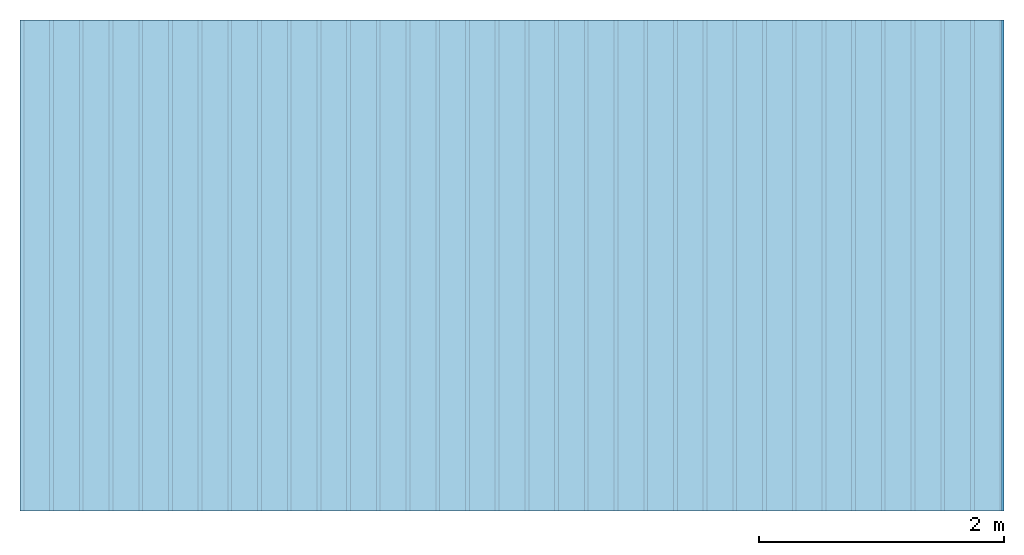
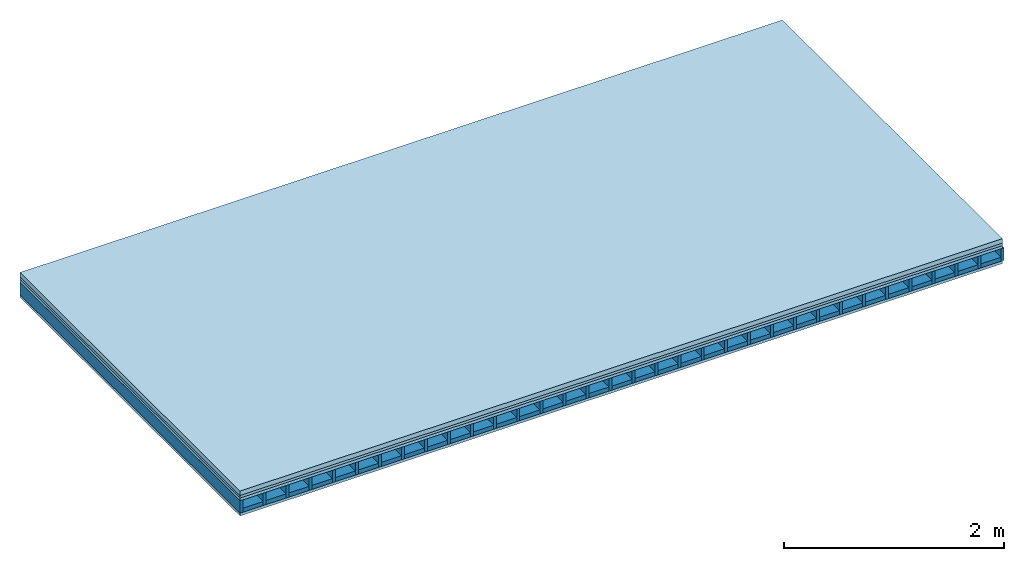
# One storey: 4 plates, 2 members, 1 element without a shape of its own.
"""IFC4 building model written with IfcOpenShell, lengths in metres."""

from ifc_helpers import new_model, si_unit, derived_unit, direction, frame, frame_2d, origin, origin_with_axes, place, context, project, spatial, rectangle, extrude, material, layer, layer_set, type_object, element, aggregate, save


model = new_model("IFC4")

# Units and contexts
plan_context = context("Plan", 3, precision=1e-05, world=origin(), true_north=direction((0.0, 1.0)))
model_context = context("Model", 3, precision=1e-05, world=origin(), true_north=direction((0.0, 1.0)))
ifc_project = project(units=[si_unit("LENGTHUNIT", "METRE"), derived_unit("SOUNDPRESSUREUNIT", [(si_unit("PRESSUREUNIT", "PASCAL", prefix="MICRO"), 0)]), si_unit("ENERGYUNIT", "JOULE", prefix="MEGA"), si_unit("MASSUNIT", "GRAM", prefix="KILO"), derived_unit("THERMALTRANSMITTANCEUNIT", [(si_unit("POWERUNIT", "WATT"), 1), (si_unit("AREAUNIT", "SQUARE_METRE"), -1), (si_unit("THERMODYNAMICTEMPERATUREUNIT", "KELVIN"), -1)]), derived_unit("AREADENSITYUNIT", [(si_unit("MASSUNIT", "GRAM", prefix="KILO"), 1), (si_unit("AREAUNIT", "SQUARE_METRE"), -1)]), derived_unit("USERDEFINED", [(si_unit("ENERGYUNIT", "JOULE", prefix="MEGA"), 1), (si_unit("AREAUNIT", "SQUARE_METRE"), -1)])], contexts=[plan_context, model_context])

# Site, building, storey
site = spatial("IfcSite", under=ifc_project)
building_placement = place(None, origin())
building = spatial("IfcBuilding", under=site, at=building_placement)
storey_placement = place(building_placement, origin())
storey = spatial("IfcBuildingStorey", under=building, at=storey_placement)

# Slab, members, plates
ifc_material_1 = material(Name="Cement screed", Category="04.006")
ifc_layer_1 = layer(ifc_material_1, 0.05, Name="On-material")
ifc_material_2 = material()
ifc_layer_2 = layer(ifc_material_2, 0.027, Name="Impact sound insulation")
ifc_material_3 = material(Name="surface element sheathing above")
ifc_layer_3 = layer(ifc_material_3, 0.031, Name="Sub-floor")
ifc_layer_4 = layer(None, 0.138, Name="Supporting structure")
ifc_material_4 = material(Name="surface element sheathing below")
ifc_layer_5 = layer(ifc_material_4, 0.031, Name="Lower layer 1")
ifc_layer_set = layer_set([ifc_layer_1, ifc_layer_2, ifc_layer_3, ifc_layer_4, ifc_layer_5])
slab_type = type_object("IfcSlabType", Name="A0030", PredefinedType="NOTDEFINED", material=ifc_layer_set)
slab_placement = place(None, frame((0.0, 0.0, 0.0), z_axis=(0.0, 0.0, -1.0), x_axis=(1.0, 0.0, 0.0)))
slab = element("IfcSlab", 1, at=slab_placement, inside=storey, type_object=slab_type, material=ifc_layer_set, Name="Slab #1")
ifc_material_5 = material(Name="surface element LFE")
member_1_placement = place(slab_placement, origin())
member_1 = element("IfcMember", 2, at=member_1_placement, material=ifc_material_5, Name="Supporting structure", context=plan_context, shape_type="SweptSolid", body=[
    extrude(rectangle(XDim=0.031, YDim=0.138, at=frame_2d((0.0155, 0.069), x_axis=(1.0, 0.0))), frame((0.0, 4.0, 0.108), z_axis=(0.0, -1.0, 0.0), x_axis=(1.0, 0.0, 0.0)), (0.0, 0.0, 1.0), 4.0),
    extrude(rectangle(XDim=0.031, YDim=0.138, at=frame_2d((0.0155, 0.069), x_axis=(1.0, 0.0))), frame((0.242, 4.0, 0.108), z_axis=(0.0, -1.0, 0.0), x_axis=(1.0, 0.0, 0.0)), (0.0, 0.0, 1.0), 4.0),
    extrude(rectangle(XDim=0.031, YDim=0.138, at=frame_2d((0.0155, 0.069), x_axis=(1.0, 0.0))), frame((0.484, 4.0, 0.108), z_axis=(0.0, -1.0, 0.0), x_axis=(1.0, 0.0, 0.0)), (0.0, 0.0, 1.0), 4.0),
    extrude(rectangle(XDim=0.031, YDim=0.138, at=frame_2d((0.0155, 0.069), x_axis=(1.0, 0.0))), frame((0.726, 4.0, 0.108), z_axis=(0.0, -1.0, 0.0), x_axis=(1.0, 0.0, 0.0)), (0.0, 0.0, 1.0), 4.0),
    extrude(rectangle(XDim=0.031, YDim=0.138, at=frame_2d((0.0155, 0.069), x_axis=(1.0, 0.0))), frame((0.968, 4.0, 0.108), z_axis=(0.0, -1.0, 0.0), x_axis=(1.0, 0.0, 0.0)), (0.0, 0.0, 1.0), 4.0),
    extrude(rectangle(XDim=0.031, YDim=0.138, at=frame_2d((0.0155, 0.069), x_axis=(1.0, 0.0))), frame((1.21, 4.0, 0.108), z_axis=(0.0, -1.0, 0.0), x_axis=(1.0, 0.0, 0.0)), (0.0, 0.0, 1.0), 4.0),
    extrude(rectangle(XDim=0.031, YDim=0.138, at=frame_2d((0.0155, 0.069), x_axis=(1.0, 0.0))), frame((1.452, 4.0, 0.108), z_axis=(0.0, -1.0, 0.0), x_axis=(1.0, 0.0, 0.0)), (0.0, 0.0, 1.0), 4.0),
    extrude(rectangle(XDim=0.031, YDim=0.138, at=frame_2d((0.0155, 0.069), x_axis=(1.0, 0.0))), frame((1.694, 4.0, 0.108), z_axis=(0.0, -1.0, 0.0), x_axis=(1.0, 0.0, 0.0)), (0.0, 0.0, 1.0), 4.0),
    extrude(rectangle(XDim=0.031, YDim=0.138, at=frame_2d((0.0155, 0.069), x_axis=(1.0, 0.0))), frame((1.936, 4.0, 0.108), z_axis=(0.0, -1.0, 0.0), x_axis=(1.0, 0.0, 0.0)), (0.0, 0.0, 1.0), 4.0),
    extrude(rectangle(XDim=0.031, YDim=0.138, at=frame_2d((0.0155, 0.069), x_axis=(1.0, 0.0))), frame((2.178, 4.0, 0.108), z_axis=(0.0, -1.0, 0.0), x_axis=(1.0, 0.0, 0.0)), (0.0, 0.0, 1.0), 4.0),
    extrude(rectangle(XDim=0.031, YDim=0.138, at=frame_2d((0.0155, 0.069), x_axis=(1.0, 0.0))), frame((2.42, 4.0, 0.108), z_axis=(0.0, -1.0, 0.0), x_axis=(1.0, 0.0, 0.0)), (0.0, 0.0, 1.0), 4.0),
    extrude(rectangle(XDim=0.031, YDim=0.138, at=frame_2d((0.0155, 0.069), x_axis=(1.0, 0.0))), frame((2.662, 4.0, 0.108), z_axis=(0.0, -1.0, 0.0), x_axis=(1.0, 0.0, 0.0)), (0.0, 0.0, 1.0), 4.0),
    extrude(rectangle(XDim=0.031, YDim=0.138, at=frame_2d((0.0155, 0.069), x_axis=(1.0, 0.0))), frame((2.904, 4.0, 0.108), z_axis=(0.0, -1.0, 0.0), x_axis=(1.0, 0.0, 0.0)), (0.0, 0.0, 1.0), 4.0),
    extrude(rectangle(XDim=0.031, YDim=0.138, at=frame_2d((0.0155, 0.069), x_axis=(1.0, 0.0))), frame((3.146, 4.0, 0.108), z_axis=(0.0, -1.0, 0.0), x_axis=(1.0, 0.0, 0.0)), (0.0, 0.0, 1.0), 4.0),
    extrude(rectangle(XDim=0.031, YDim=0.138, at=frame_2d((0.0155, 0.069), x_axis=(1.0, 0.0))), frame((3.388, 4.0, 0.108), z_axis=(0.0, -1.0, 0.0), x_axis=(1.0, 0.0, 0.0)), (0.0, 0.0, 1.0), 4.0),
    extrude(rectangle(XDim=0.031, YDim=0.138, at=frame_2d((0.0155, 0.069), x_axis=(1.0, 0.0))), frame((3.63, 4.0, 0.108), z_axis=(0.0, -1.0, 0.0), x_axis=(1.0, 0.0, 0.0)), (0.0, 0.0, 1.0), 4.0),
    extrude(rectangle(XDim=0.031, YDim=0.138, at=frame_2d((0.0155, 0.069), x_axis=(1.0, 0.0))), frame((3.872, 4.0, 0.108), z_axis=(0.0, -1.0, 0.0), x_axis=(1.0, 0.0, 0.0)), (0.0, 0.0, 1.0), 4.0),
    extrude(rectangle(XDim=0.031, YDim=0.138, at=frame_2d((0.0155, 0.069), x_axis=(1.0, 0.0))), frame((4.114, 4.0, 0.108), z_axis=(0.0, -1.0, 0.0), x_axis=(1.0, 0.0, 0.0)), (0.0, 0.0, 1.0), 4.0),
    extrude(rectangle(XDim=0.031, YDim=0.138, at=frame_2d((0.0155, 0.069), x_axis=(1.0, 0.0))), frame((4.356, 4.0, 0.108), z_axis=(0.0, -1.0, 0.0), x_axis=(1.0, 0.0, 0.0)), (0.0, 0.0, 1.0), 4.0),
    extrude(rectangle(XDim=0.031, YDim=0.138, at=frame_2d((0.0155, 0.069), x_axis=(1.0, 0.0))), frame((4.598, 4.0, 0.108), z_axis=(0.0, -1.0, 0.0), x_axis=(1.0, 0.0, 0.0)), (0.0, 0.0, 1.0), 4.0),
    extrude(rectangle(XDim=0.031, YDim=0.138, at=frame_2d((0.0155, 0.069), x_axis=(1.0, 0.0))), frame((4.84, 4.0, 0.108), z_axis=(0.0, -1.0, 0.0), x_axis=(1.0, 0.0, 0.0)), (0.0, 0.0, 1.0), 4.0),
    extrude(rectangle(XDim=0.031, YDim=0.138, at=frame_2d((0.0155, 0.069), x_axis=(1.0, 0.0))), frame((5.082, 4.0, 0.108), z_axis=(0.0, -1.0, 0.0), x_axis=(1.0, 0.0, 0.0)), (0.0, 0.0, 1.0), 4.0),
    extrude(rectangle(XDim=0.031, YDim=0.138, at=frame_2d((0.0155, 0.069), x_axis=(1.0, 0.0))), frame((5.324, 4.0, 0.108), z_axis=(0.0, -1.0, 0.0), x_axis=(1.0, 0.0, 0.0)), (0.0, 0.0, 1.0), 4.0),
    extrude(rectangle(XDim=0.031, YDim=0.138, at=frame_2d((0.0155, 0.069), x_axis=(1.0, 0.0))), frame((5.566, 4.0, 0.108), z_axis=(0.0, -1.0, 0.0), x_axis=(1.0, 0.0, 0.0)), (0.0, 0.0, 1.0), 4.0),
    extrude(rectangle(XDim=0.031, YDim=0.138, at=frame_2d((0.0155, 0.069), x_axis=(1.0, 0.0))), frame((5.808, 4.0, 0.108), z_axis=(0.0, -1.0, 0.0), x_axis=(1.0, 0.0, 0.0)), (0.0, 0.0, 1.0), 4.0),
    extrude(rectangle(XDim=0.031, YDim=0.138, at=frame_2d((0.0155, 0.069), x_axis=(1.0, 0.0))), frame((6.05, 4.0, 0.108), z_axis=(0.0, -1.0, 0.0), x_axis=(1.0, 0.0, 0.0)), (0.0, 0.0, 1.0), 4.0),
    extrude(rectangle(XDim=0.031, YDim=0.138, at=frame_2d((0.0155, 0.069), x_axis=(1.0, 0.0))), frame((6.292, 4.0, 0.108), z_axis=(0.0, -1.0, 0.0), x_axis=(1.0, 0.0, 0.0)), (0.0, 0.0, 1.0), 4.0),
    extrude(rectangle(XDim=0.031, YDim=0.138, at=frame_2d((0.0155, 0.069), x_axis=(1.0, 0.0))), frame((6.534, 4.0, 0.108), z_axis=(0.0, -1.0, 0.0), x_axis=(1.0, 0.0, 0.0)), (0.0, 0.0, 1.0), 4.0),
    extrude(rectangle(XDim=0.031, YDim=0.138, at=frame_2d((0.0155, 0.069), x_axis=(1.0, 0.0))), frame((6.776, 4.0, 0.108), z_axis=(0.0, -1.0, 0.0), x_axis=(1.0, 0.0, 0.0)), (0.0, 0.0, 1.0), 4.0),
    extrude(rectangle(XDim=0.031, YDim=0.138, at=frame_2d((0.0155, 0.069), x_axis=(1.0, 0.0))), frame((7.018, 4.0, 0.108), z_axis=(0.0, -1.0, 0.0), x_axis=(1.0, 0.0, 0.0)), (0.0, 0.0, 1.0), 4.0),
    extrude(rectangle(XDim=0.031, YDim=0.138, at=frame_2d((0.0155, 0.069), x_axis=(1.0, 0.0))), frame((7.26, 4.0, 0.108), z_axis=(0.0, -1.0, 0.0), x_axis=(1.0, 0.0, 0.0)), (0.0, 0.0, 1.0), 4.0),
    extrude(rectangle(XDim=0.031, YDim=0.138, at=frame_2d((0.0155, 0.069), x_axis=(1.0, 0.0))), frame((7.502, 4.0, 0.108), z_axis=(0.0, -1.0, 0.0), x_axis=(1.0, 0.0, 0.0)), (0.0, 0.0, 1.0), 4.0),
    extrude(rectangle(XDim=0.031, YDim=0.138, at=frame_2d((0.0155, 0.069), x_axis=(1.0, 0.0))), frame((7.744, 4.0, 0.108), z_axis=(0.0, -1.0, 0.0), x_axis=(1.0, 0.0, 0.0)), (0.0, 0.0, 1.0), 4.0),
    extrude(rectangle(XDim=0.031, YDim=0.138, at=frame_2d((0.0155, 0.069), x_axis=(1.0, 0.0))), frame((7.986, 4.0, 0.108), z_axis=(0.0, -1.0, 0.0), x_axis=(1.0, 0.0, 0.0)), (0.0, 0.0, 1.0), 4.0),
])
ifc_material_6 = material()
member_2_placement = place(slab_placement, origin())
member_2 = element("IfcMember", 3, at=member_2_placement, material=ifc_material_6, Name="in supporting structure", context=plan_context, shape_type="SweptSolid", body=[
    extrude(rectangle(XDim=0.211, YDim=0.045, at=frame_2d((0.1055, 0.0225), x_axis=(1.0, 0.0))), frame((0.031, 4.0, 0.201), z_axis=(0.0, -1.0, 0.0), x_axis=(1.0, 0.0, 0.0)), (0.0, 0.0, 1.0), 4.0),
    extrude(rectangle(XDim=0.211, YDim=0.045, at=frame_2d((0.1055, 0.0225), x_axis=(1.0, 0.0))), frame((0.273, 4.0, 0.201), z_axis=(0.0, -1.0, 0.0), x_axis=(1.0, 0.0, 0.0)), (0.0, 0.0, 1.0), 4.0),
    extrude(rectangle(XDim=0.211, YDim=0.045, at=frame_2d((0.1055, 0.0225), x_axis=(1.0, 0.0))), frame((0.515, 4.0, 0.201), z_axis=(0.0, -1.0, 0.0), x_axis=(1.0, 0.0, 0.0)), (0.0, 0.0, 1.0), 4.0),
    extrude(rectangle(XDim=0.211, YDim=0.045, at=frame_2d((0.1055, 0.0225), x_axis=(1.0, 0.0))), frame((0.757, 4.0, 0.201), z_axis=(0.0, -1.0, 0.0), x_axis=(1.0, 0.0, 0.0)), (0.0, 0.0, 1.0), 4.0),
    extrude(rectangle(XDim=0.211, YDim=0.045, at=frame_2d((0.1055, 0.0225), x_axis=(1.0, 0.0))), frame((0.999, 4.0, 0.201), z_axis=(0.0, -1.0, 0.0), x_axis=(1.0, 0.0, 0.0)), (0.0, 0.0, 1.0), 4.0),
    extrude(rectangle(XDim=0.211, YDim=0.045, at=frame_2d((0.1055, 0.0225), x_axis=(1.0, 0.0))), frame((1.241, 4.0, 0.201), z_axis=(0.0, -1.0, 0.0), x_axis=(1.0, 0.0, 0.0)), (0.0, 0.0, 1.0), 4.0),
    extrude(rectangle(XDim=0.211, YDim=0.045, at=frame_2d((0.1055, 0.0225), x_axis=(1.0, 0.0))), frame((1.483, 4.0, 0.201), z_axis=(0.0, -1.0, 0.0), x_axis=(1.0, 0.0, 0.0)), (0.0, 0.0, 1.0), 4.0),
    extrude(rectangle(XDim=0.211, YDim=0.045, at=frame_2d((0.1055, 0.0225), x_axis=(1.0, 0.0))), frame((1.725, 4.0, 0.201), z_axis=(0.0, -1.0, 0.0), x_axis=(1.0, 0.0, 0.0)), (0.0, 0.0, 1.0), 4.0),
    extrude(rectangle(XDim=0.211, YDim=0.045, at=frame_2d((0.1055, 0.0225), x_axis=(1.0, 0.0))), frame((1.967, 4.0, 0.201), z_axis=(0.0, -1.0, 0.0), x_axis=(1.0, 0.0, 0.0)), (0.0, 0.0, 1.0), 4.0),
    extrude(rectangle(XDim=0.211, YDim=0.045, at=frame_2d((0.1055, 0.0225), x_axis=(1.0, 0.0))), frame((2.209, 4.0, 0.201), z_axis=(0.0, -1.0, 0.0), x_axis=(1.0, 0.0, 0.0)), (0.0, 0.0, 1.0), 4.0),
    extrude(rectangle(XDim=0.211, YDim=0.045, at=frame_2d((0.1055, 0.0225), x_axis=(1.0, 0.0))), frame((2.451, 4.0, 0.201), z_axis=(0.0, -1.0, 0.0), x_axis=(1.0, 0.0, 0.0)), (0.0, 0.0, 1.0), 4.0),
    extrude(rectangle(XDim=0.211, YDim=0.045, at=frame_2d((0.1055, 0.0225), x_axis=(1.0, 0.0))), frame((2.693, 4.0, 0.201), z_axis=(0.0, -1.0, 0.0), x_axis=(1.0, 0.0, 0.0)), (0.0, 0.0, 1.0), 4.0),
    extrude(rectangle(XDim=0.211, YDim=0.045, at=frame_2d((0.1055, 0.0225), x_axis=(1.0, 0.0))), frame((2.935, 4.0, 0.201), z_axis=(0.0, -1.0, 0.0), x_axis=(1.0, 0.0, 0.0)), (0.0, 0.0, 1.0), 4.0),
    extrude(rectangle(XDim=0.211, YDim=0.045, at=frame_2d((0.1055, 0.0225), x_axis=(1.0, 0.0))), frame((3.177, 4.0, 0.201), z_axis=(0.0, -1.0, 0.0), x_axis=(1.0, 0.0, 0.0)), (0.0, 0.0, 1.0), 4.0),
    extrude(rectangle(XDim=0.211, YDim=0.045, at=frame_2d((0.1055, 0.0225), x_axis=(1.0, 0.0))), frame((3.419, 4.0, 0.201), z_axis=(0.0, -1.0, 0.0), x_axis=(1.0, 0.0, 0.0)), (0.0, 0.0, 1.0), 4.0),
    extrude(rectangle(XDim=0.211, YDim=0.045, at=frame_2d((0.1055, 0.0225), x_axis=(1.0, 0.0))), frame((3.661, 4.0, 0.201), z_axis=(0.0, -1.0, 0.0), x_axis=(1.0, 0.0, 0.0)), (0.0, 0.0, 1.0), 4.0),
    extrude(rectangle(XDim=0.211, YDim=0.045, at=frame_2d((0.1055, 0.0225), x_axis=(1.0, 0.0))), frame((3.903, 4.0, 0.201), z_axis=(0.0, -1.0, 0.0), x_axis=(1.0, 0.0, 0.0)), (0.0, 0.0, 1.0), 4.0),
    extrude(rectangle(XDim=0.211, YDim=0.045, at=frame_2d((0.1055, 0.0225), x_axis=(1.0, 0.0))), frame((4.145, 4.0, 0.201), z_axis=(0.0, -1.0, 0.0), x_axis=(1.0, 0.0, 0.0)), (0.0, 0.0, 1.0), 4.0),
    extrude(rectangle(XDim=0.211, YDim=0.045, at=frame_2d((0.1055, 0.0225), x_axis=(1.0, 0.0))), frame((4.387, 4.0, 0.201), z_axis=(0.0, -1.0, 0.0), x_axis=(1.0, 0.0, 0.0)), (0.0, 0.0, 1.0), 4.0),
    extrude(rectangle(XDim=0.211, YDim=0.045, at=frame_2d((0.1055, 0.0225), x_axis=(1.0, 0.0))), frame((4.629, 4.0, 0.201), z_axis=(0.0, -1.0, 0.0), x_axis=(1.0, 0.0, 0.0)), (0.0, 0.0, 1.0), 4.0),
    extrude(rectangle(XDim=0.211, YDim=0.045, at=frame_2d((0.1055, 0.0225), x_axis=(1.0, 0.0))), frame((4.871, 4.0, 0.201), z_axis=(0.0, -1.0, 0.0), x_axis=(1.0, 0.0, 0.0)), (0.0, 0.0, 1.0), 4.0),
    extrude(rectangle(XDim=0.211, YDim=0.045, at=frame_2d((0.1055, 0.0225), x_axis=(1.0, 0.0))), frame((5.113, 4.0, 0.201), z_axis=(0.0, -1.0, 0.0), x_axis=(1.0, 0.0, 0.0)), (0.0, 0.0, 1.0), 4.0),
    extrude(rectangle(XDim=0.211, YDim=0.045, at=frame_2d((0.1055, 0.0225), x_axis=(1.0, 0.0))), frame((5.355, 4.0, 0.201), z_axis=(0.0, -1.0, 0.0), x_axis=(1.0, 0.0, 0.0)), (0.0, 0.0, 1.0), 4.0),
    extrude(rectangle(XDim=0.211, YDim=0.045, at=frame_2d((0.1055, 0.0225), x_axis=(1.0, 0.0))), frame((5.597, 4.0, 0.201), z_axis=(0.0, -1.0, 0.0), x_axis=(1.0, 0.0, 0.0)), (0.0, 0.0, 1.0), 4.0),
    extrude(rectangle(XDim=0.211, YDim=0.045, at=frame_2d((0.1055, 0.0225), x_axis=(1.0, 0.0))), frame((5.839, 4.0, 0.201), z_axis=(0.0, -1.0, 0.0), x_axis=(1.0, 0.0, 0.0)), (0.0, 0.0, 1.0), 4.0),
    extrude(rectangle(XDim=0.211, YDim=0.045, at=frame_2d((0.1055, 0.0225), x_axis=(1.0, 0.0))), frame((6.081, 4.0, 0.201), z_axis=(0.0, -1.0, 0.0), x_axis=(1.0, 0.0, 0.0)), (0.0, 0.0, 1.0), 4.0),
    extrude(rectangle(XDim=0.211, YDim=0.045, at=frame_2d((0.1055, 0.0225), x_axis=(1.0, 0.0))), frame((6.323, 4.0, 0.201), z_axis=(0.0, -1.0, 0.0), x_axis=(1.0, 0.0, 0.0)), (0.0, 0.0, 1.0), 4.0),
    extrude(rectangle(XDim=0.211, YDim=0.045, at=frame_2d((0.1055, 0.0225), x_axis=(1.0, 0.0))), frame((6.565, 4.0, 0.201), z_axis=(0.0, -1.0, 0.0), x_axis=(1.0, 0.0, 0.0)), (0.0, 0.0, 1.0), 4.0),
    extrude(rectangle(XDim=0.211, YDim=0.045, at=frame_2d((0.1055, 0.0225), x_axis=(1.0, 0.0))), frame((6.807, 4.0, 0.201), z_axis=(0.0, -1.0, 0.0), x_axis=(1.0, 0.0, 0.0)), (0.0, 0.0, 1.0), 4.0),
    extrude(rectangle(XDim=0.211, YDim=0.045, at=frame_2d((0.1055, 0.0225), x_axis=(1.0, 0.0))), frame((7.049, 4.0, 0.201), z_axis=(0.0, -1.0, 0.0), x_axis=(1.0, 0.0, 0.0)), (0.0, 0.0, 1.0), 4.0),
    extrude(rectangle(XDim=0.211, YDim=0.045, at=frame_2d((0.1055, 0.0225), x_axis=(1.0, 0.0))), frame((7.291, 4.0, 0.201), z_axis=(0.0, -1.0, 0.0), x_axis=(1.0, 0.0, 0.0)), (0.0, 0.0, 1.0), 4.0),
    extrude(rectangle(XDim=0.211, YDim=0.045, at=frame_2d((0.1055, 0.0225), x_axis=(1.0, 0.0))), frame((7.533, 4.0, 0.201), z_axis=(0.0, -1.0, 0.0), x_axis=(1.0, 0.0, 0.0)), (0.0, 0.0, 1.0), 4.0),
    extrude(rectangle(XDim=0.211, YDim=0.045, at=frame_2d((0.1055, 0.0225), x_axis=(1.0, 0.0))), frame((7.775, 4.0, 0.201), z_axis=(0.0, -1.0, 0.0), x_axis=(1.0, 0.0, 0.0)), (0.0, 0.0, 1.0), 4.0),
])
plate_1_placement = place(slab_placement, origin())
plate_1 = element("IfcPlate", 4, at=plate_1_placement, material=ifc_material_1, Name="On-material", context=plan_context, shape_type="SweptSolid", body=[
    extrude(rectangle(XDim=8.0, YDim=4.0, at=frame_2d((4.0, 2.0), x_axis=(1.0, 0.0))), origin_with_axes(), (0.0, 0.0, 1.0), 0.05),
])
plate_2_placement = place(slab_placement, origin())
plate_2 = element("IfcPlate", 5, at=plate_2_placement, material=ifc_material_2, Name="Impact sound insulation", context=plan_context, shape_type="SweptSolid", body=[
    extrude(rectangle(XDim=8.0, YDim=4.0, at=frame_2d((4.0, 2.0), x_axis=(1.0, 0.0))), frame((0.0, 0.0, 0.05), z_axis=(0.0, 0.0, 1.0), x_axis=(1.0, 0.0, 0.0)), (0.0, 0.0, 1.0), 0.027),
])
plate_3_placement = place(slab_placement, origin())
plate_3 = element("IfcPlate", 6, at=plate_3_placement, material=ifc_material_3, Name="Sub-floor", context=plan_context, shape_type="SweptSolid", body=[
    extrude(rectangle(XDim=8.0, YDim=4.0, at=frame_2d((4.0, 2.0), x_axis=(1.0, 0.0))), frame((0.0, 0.0, 0.077), z_axis=(0.0, 0.0, 1.0), x_axis=(1.0, 0.0, 0.0)), (0.0, 0.0, 1.0), 0.031),
])
plate_4_placement = place(slab_placement, origin())
plate_4 = element("IfcPlate", 7, at=plate_4_placement, material=ifc_material_4, Name="Lower layer 1", context=plan_context, shape_type="SweptSolid", body=[
    extrude(rectangle(XDim=8.0, YDim=4.0, at=frame_2d((4.0, 2.0), x_axis=(1.0, 0.0))), frame((0.0, 0.0, 0.246), z_axis=(0.0, 0.0, 1.0), x_axis=(1.0, 0.0, 0.0)), (0.0, 0.0, 1.0), 0.031),
])
aggregate(slab, [plate_1, plate_2, plate_3, member_1, member_2, plate_4])

save(model, "model.ifc")
